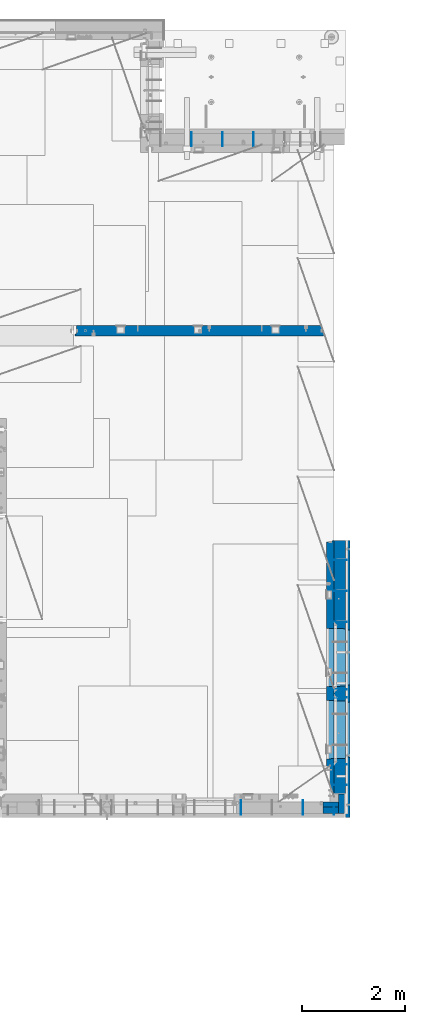
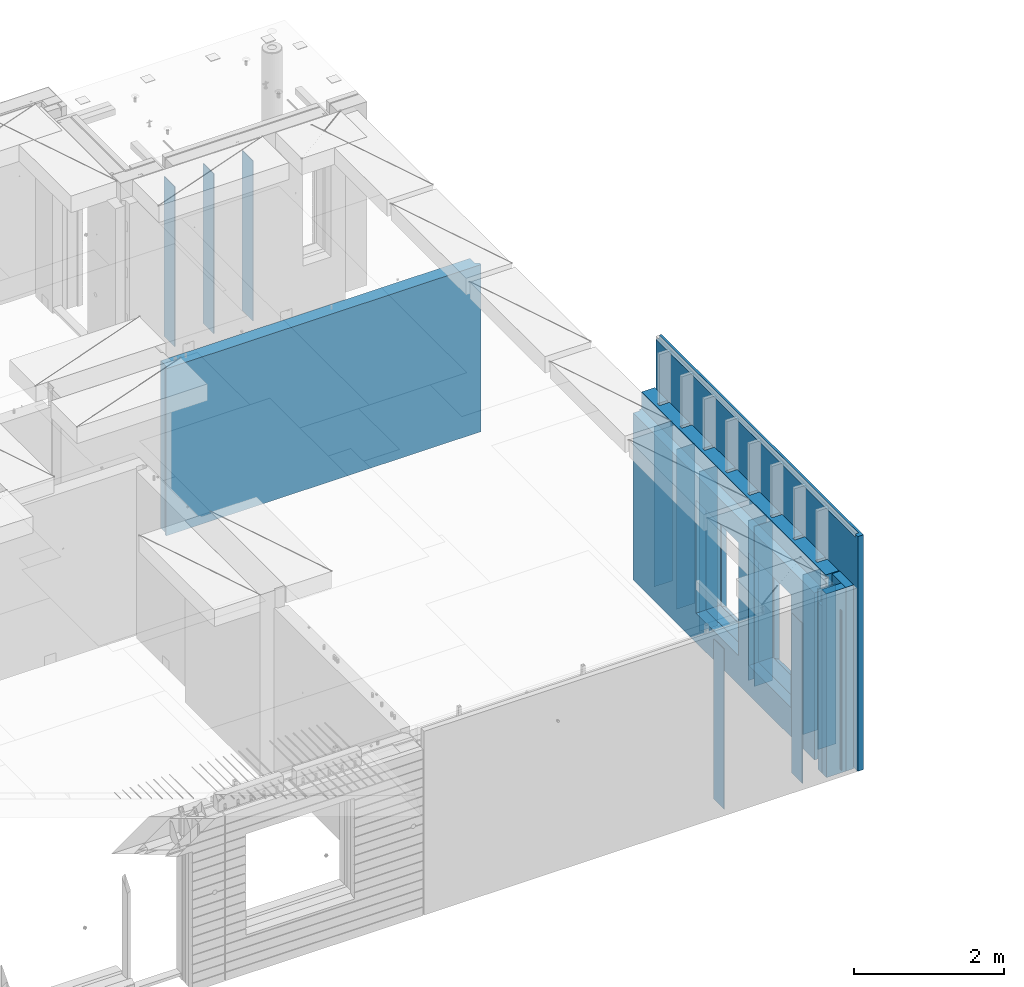
# One storey, part 206 of 309: 20 walls, 4 elements without a shape of their own.
"""IFC2X3 building model written with IfcOpenShell, lengths in millimetres."""

import ifcopenshell
import ifcopenshell.guid

model = None  # the IFC model being written
_history = None  # IfcOwnerHistory: only IFC2X3 demands one
_inside = {}  # id of a spatial element -> (the spatial element, [elements in it])
_under = {}  # id of a project, library or spatial element -> (it, [spatial elements below it])
_declared = {}  # id of a project -> (the project, [libraries it declares])
_typed = {}  # id of a type object -> (the type object, [elements of that type])
_made_of = {}  # id of a material, layer set ... -> (it, [elements and type objects made of it])


def new_model(schema):
    """Start an empty IFC model of exactly this schema.

    Asked for "IFC4X3", IfcOpenShell would pick the latest addendum, in which some entities
    have other attributes; the version numbers below select the first issue.
    IFC2X3 requires an IfcOwnerHistory on every rooted entity: one is made here for all.
    """
    global model, _history
    if schema == "IFC4X3":
        model = ifcopenshell.file(schema_version=(4, 3, 0, 0))
    else:
        model = ifcopenshell.file(schema=schema)
    _inside.clear()
    _under.clear()
    _declared.clear()
    _typed.clear()
    _made_of.clear()
    _history = None
    if model.schema == "IFC2X3":
        org = make("IfcOrganization", Name="unknown")
        user = make(
            "IfcPersonAndOrganization",
            ThePerson=make("IfcPerson", FamilyName="unknown"),
            TheOrganization=org,
        )
        app = make(
            "IfcApplication",
            ApplicationDeveloper=org,
            Version="unknown",
            ApplicationFullName="unknown",
            ApplicationIdentifier="unknown",
        )
        _history = make(
            "IfcOwnerHistory",
            OwningUser=user,
            OwningApplication=app,
            ChangeAction="ADDED",
            CreationDate=0,
        )
    return model


def make(cls, **values):
    """One entity of the class cls with the attributes given. An attribute that is None is left unset."""
    return model.create_entity(
        cls, **{name: value for name, value in values.items() if value is not None}
    )


def rooted(cls, **values):
    """An entity with a GlobalId (a new one), such as an element, a storey or a relation."""
    return make(cls, GlobalId=ifcopenshell.guid.new(), OwnerHistory=_history, **values)


def si_unit(unit_type, name, prefix=None):
    """IfcSIUnit, for example si_unit("LENGTHUNIT", "METRE", prefix="MILLI")."""
    return make("IfcSIUnit", UnitType=unit_type, Prefix=prefix, Name=name)


def assignment(units):
    """IfcUnitAssignment: the units of a project."""
    return None if units is None else make("IfcUnitAssignment", Units=units)


def point(xyz):
    """IfcCartesianPoint."""
    return None if xyz is None else make("IfcCartesianPoint", Coordinates=xyz)


def direction(xyz):
    """IfcDirection."""
    return None if xyz is None else make("IfcDirection", DirectionRatios=xyz)


def frame(location, z_axis=None, x_axis=None):
    """IfcAxis2Placement3D, a coordinate frame: its origin and axes. An axis left out is left unset."""
    return make(
        "IfcAxis2Placement3D",
        Location=point(location),
        Axis=direction(z_axis),
        RefDirection=direction(x_axis),
    )


def origin_with_axes():
    """The frame at (0, 0, 0) with the z axis (0, 0, 1) and the x axis (1, 0, 0) written out."""
    return frame((0.0, 0.0, 0.0), z_axis=(0.0, 0.0, 1.0), x_axis=(1.0, 0.0, 0.0))


def place(relative_to, where):
    """IfcLocalPlacement: puts the frame where relative to a parent placement (None: the world)."""
    return make(
        "IfcLocalPlacement", PlacementRelTo=relative_to, RelativePlacement=where
    )


def context(
    kind, dimensions, precision=None, world=None, true_north=None, identifier=None
):
    """IfcGeometricRepresentationContext, for example the 3D "Model" context."""
    return make(
        "IfcGeometricRepresentationContext",
        ContextIdentifier=identifier,
        ContextType=kind,
        CoordinateSpaceDimension=dimensions,
        Precision=precision,
        WorldCoordinateSystem=world,
        TrueNorth=true_north,
    )


def subcontext(parent, identifier, kind, view, scale=None):
    """IfcGeometricRepresentationSubContext, for example "Body" below "Model"."""
    return make(
        "IfcGeometricRepresentationSubContext",
        ContextIdentifier=identifier,
        ContextType=kind,
        ParentContext=parent,
        TargetScale=scale,
        TargetView=view,
    )


def project(units=None, contexts=None):
    """IfcProject with its units and contexts."""
    return rooted(
        "IfcProject",
        Name="project",
        RepresentationContexts=contexts,
        UnitsInContext=assignment(units),
    )


def spatial(cls, under=None, at=None, **own):
    """A site, building, storey or space (cls), placed at a placement, below another one or the project."""
    s = rooted(cls, ObjectPlacement=at, **own)
    if under is not None:
        _under.setdefault(under.id(), (under, []))[1].append(s)
    return s


def faces_of(points, faces, orient=None, outer=None):
    """IfcFace entities. A face is a list of loops; a loop is a list of indices into points, from 0.

    orient and outer hold one flag for each loop. By default every Orientation is true, the
    first loop of a face is its IfcFaceOuterBound and the others are IfcFaceBound.
    """
    made = []
    for i, loops in enumerate(faces):
        bounds = []
        for j, loop in enumerate(loops):
            is_outer = j == 0 if outer is None else outer[i][j]
            bounds.append(
                make(
                    "IfcFaceOuterBound" if is_outer else "IfcFaceBound",
                    Bound=make("IfcPolyLoop", Polygon=[points[k] for k in loop]),
                    Orientation=True if orient is None else orient[i][j],
                )
            )
        made.append(make("IfcFace", Bounds=bounds))
    return made


def faceted_brep(points, faces, orient=None, outer=None, voids=None):
    """IfcFacetedBrep: a solid bounded by flat faces; with voids (closed shells), ...WithVoids."""
    shared = [point(p) for p in points]
    hull = make("IfcClosedShell", CfsFaces=faces_of(shared, faces, orient, outer))
    if voids is None:
        return make("IfcFacetedBrep", Outer=hull)
    return make(
        "IfcFacetedBrepWithVoids",
        Outer=hull,
        Voids=[
            make(cls, CfsFaces=faces_of(shared, fs, o, b)) for cls, fs, o, b in voids
        ],
    )


def shape(context_of_items, identifier, shape_type, items):
    """IfcShapeRepresentation: the items that make up one representation, for example the "Body"."""
    return make(
        "IfcShapeRepresentation",
        ContextOfItems=context_of_items,
        RepresentationIdentifier=identifier,
        RepresentationType=shape_type,
        Items=items,
    )


def material(Name=None, Category=None):
    """IfcMaterial."""
    return make("IfcMaterial", Name=Name, Category=Category)


def made_of(thing, what):
    """Note that an element or type object is made of a material, layer set ...; save() writes the relation."""
    if what is not None:
        _made_of.setdefault(what.id(), (what, []))[1].append(thing)
    return thing


def type_object(cls, material=None, **own):
    """A type object (cls), such as IfcWallType, which elements share."""
    return made_of(rooted(cls, **own), material)


def element(
    cls,
    number,
    at=None,
    inside=None,
    cuts=None,
    type_object=None,
    material=None,
    context=None,
    identifier="Body",
    shape_type=None,
    held_by="IfcProductDefinitionShape",
    body=None,
    shapes=None,
    **own,
):
    """One element of the class cls, such as IfcWall. Its Tag is "e" and its number.

    at: its placement. inside: the storey or other place that contains it. cuts: it is an
    opening in that element (IfcRelVoidsElement). A single representation is given by context,
    identifier, shape_type and body (its items); several are given by shapes. held_by: the class
    of the entity that holds the representations. save() writes the other relations.
    """
    e = rooted(cls, Tag="e%d" % number, ObjectPlacement=at, **own)
    if body is not None:
        shapes = [shape(context, identifier, shape_type, body)]
    if shapes is not None:
        e.Representation = make(held_by, Representations=shapes)
    if inside is not None:
        _inside.setdefault(inside.id(), (inside, []))[1].append(e)
    if cuts is not None:
        rooted(
            "IfcRelVoidsElement", RelatingBuildingElement=cuts, RelatedOpeningElement=e
        )
    if type_object is not None:
        _typed.setdefault(type_object.id(), (type_object, []))[1].append(e)
    return made_of(e, material)


def aggregate(whole, parts):
    """IfcRelAggregates: a whole, such as a stair, and the parts it consists of."""
    return rooted("IfcRelAggregates", RelatingObject=whole, RelatedObjects=parts)


def save(model, path):
    """Write the relations noted so far, then the file.

    IfcRelAggregates (storeys below a building ...), IfcRelContainedInSpatialStructure (elements
    in a storey), IfcRelDefinesByType, IfcRelAssociatesMaterial and IfcRelDeclares: one each for
    every whole, place, type object, material and project.
    """
    for whole, parts in _under.values():
        aggregate(whole, parts)
    for where, things in _inside.values():
        rooted(
            "IfcRelContainedInSpatialStructure",
            RelatedElements=things,
            RelatingStructure=where,
        )
    for kind, things in _typed.values():
        rooted("IfcRelDefinesByType", RelatedObjects=things, RelatingType=kind)
    for what, things in _made_of.values():
        rooted("IfcRelAssociatesMaterial", RelatedObjects=things, RelatingMaterial=what)
    for by, libraries in _declared.values():
        rooted("IfcRelDeclares", RelatingContext=by, RelatedDefinitions=libraries)
    model.write(path)


model = new_model("IFC2X3")

# Units and contexts
model_context = context("Model", 3, precision=1e-05, world=origin_with_axes())
body_context = subcontext(model_context, "Body", "Model", "MODEL_VIEW")
ifc_project = project(units=[si_unit("LENGTHUNIT", "METRE", prefix="MILLI"), si_unit("AREAUNIT", "SQUARE_METRE"), si_unit("VOLUMEUNIT", "CUBIC_METRE"), si_unit("MASSUNIT", "GRAM", prefix="KILO"), si_unit("TIMEUNIT", "SECOND"), si_unit("PLANEANGLEUNIT", "RADIAN"), si_unit("SOLIDANGLEUNIT", "STERADIAN"), si_unit("THERMODYNAMICTEMPERATUREUNIT", "DEGREE_CELSIUS"), si_unit("LUMINOUSINTENSITYUNIT", "LUMEN")], contexts=[model_context])

# Site, building, storey
site_placement = place(None, origin_with_axes())
site = spatial("IfcSite", under=ifc_project, at=site_placement, CompositionType="ELEMENT")
building_placement = place(site_placement, origin_with_axes())
building = spatial("IfcBuilding", under=site, at=building_placement, CompositionType="ELEMENT")
storey_placement = place(building_placement, origin_with_axes())
storey = spatial("IfcBuildingStorey", under=building, at=storey_placement, Name="7", CompositionType="ELEMENT", Elevation=0.0)

# Assembly, walls
assembly_1_placement = place(storey_placement, origin_with_axes())
assembly_1 = element("IfcElementAssembly", 1, at=assembly_1_placement, inside=storey, AssemblyPlace="NOTDEFINED", PredefinedType="REINFORCEMENT_UNIT")
ifc_material_1 = material(Name="Undefined")
wall_type_1 = type_object("IfcWallType", PredefinedType="NOTDEFINED")
wall_1_placement = place(assembly_1_placement, frame((35030.0, 9870.00028610229, 101115.0), z_axis=(0.0, 0.0, 1.0), x_axis=(1.0, 0.0, 0.0)))
wall_1 = element("IfcWall", 2, at=wall_1_placement, type_object=wall_type_1, material=ifc_material_1, Name="(PD)", context=body_context, shape_type="Brep", body=[
    faceted_brep([(0.0, 5.0, -1300.0), (0.0, 5.0, 1300.0), (280.0, 5.0, 1300.0), (280.0, 5.0, -1300.0), (0.0, -5.0, 1300.0), (280.0, -5.0, 1300.0), (0.0, -5.0, -1300.0), (280.0, -5.0, -1300.0)], [[[0, 1, 2, 3]], [[1, 4, 5, 2]], [[4, 6, 7, 5]], [[6, 0, 3, 7]], [[5, 7, 3, 2]], [[6, 4, 1, 0]]]),
])
wall_2_placement = place(assembly_1_placement, frame((35030.0, 10030.0002861023, 101115.0), z_axis=(0.0, 0.0, 1.0), x_axis=(1.0, 0.0, 0.0)))
wall_2 = element("IfcWall", 3, at=wall_2_placement, type_object=wall_type_1, material=ifc_material_1, Name="(PD)", context=body_context, shape_type="Brep", body=[
    faceted_brep([(0.0, 5.0, -1300.0), (0.0, 5.0, 1300.0), (280.0, 5.0, 1300.0), (280.0, 5.0, -1300.0), (0.0, -5.0, 1300.0), (280.0, -5.0, 1300.0), (0.0, -5.0, -1300.0), (280.0, -5.0, -1300.0)], [[[0, 1, 2, 3]], [[1, 4, 5, 2]], [[4, 6, 7, 5]], [[6, 0, 3, 7]], [[5, 7, 3, 2]], [[6, 4, 1, 0]]]),
])
wall_3_placement = place(assembly_1_placement, frame((35030.0, 8580.0, 101115.0), z_axis=(0.0, 0.0, 1.0), x_axis=(1.0, 0.0, 0.0)))
wall_3 = element("IfcWall", 4, at=wall_3_placement, type_object=wall_type_1, material=ifc_material_1, Name="(PD)", context=body_context, shape_type="Brep", body=[
    faceted_brep([(0.0, 5.0, -1300.0), (0.0, 5.0, 1300.0), (280.0, 5.0, 1300.0), (280.0, 5.0, -1300.0), (0.0, -5.0, 1300.0), (280.0, -5.0, 1300.0), (0.0, -5.0, -1300.0), (280.0, -5.0, -1300.0)], [[[0, 1, 2, 3]], [[1, 4, 5, 2]], [[4, 6, 7, 5]], [[6, 0, 3, 7]], [[5, 7, 3, 2]], [[6, 4, 1, 0]]]),
])
wall_4_placement = place(assembly_1_placement, frame((35030.0, 12540.0002861023, 101115.0), z_axis=(0.0, 0.0, 1.0), x_axis=(1.0, 0.0, 0.0)))
wall_4 = element("IfcWall", 5, at=wall_4_placement, type_object=wall_type_1, material=ifc_material_1, Name="(PD)", context=body_context, shape_type="Brep", body=[
    faceted_brep([(0.0, 5.0, -1300.0), (0.0, 5.0, 1300.0), (280.0, 5.0, 1300.0), (280.0, 5.0, -1300.0), (0.0, -5.0, 1300.0), (280.0, -5.0, 1300.0), (0.0, -5.0, -1300.0), (280.0, -5.0, -1300.0)], [[[0, 1, 2, 3]], [[1, 4, 5, 2]], [[4, 6, 7, 5]], [[6, 0, 3, 7]], [[5, 7, 3, 2]], [[6, 4, 1, 0]]]),
])
wall_5_placement = place(assembly_1_placement, frame((35030.0, 11940.0002861023, 101115.0), z_axis=(0.0, 0.0, 1.0), x_axis=(1.0, 0.0, 0.0)))
wall_5 = element("IfcWall", 6, at=wall_5_placement, type_object=wall_type_1, material=ifc_material_1, Name="(PD)", context=body_context, shape_type="Brep", body=[
    faceted_brep([(0.0, 5.0, -1300.0), (0.0, 5.0, 1300.0), (280.0, 5.0, 1300.0), (280.0, 5.0, -1300.0), (0.0, -5.0, 1300.0), (280.0, -5.0, 1300.0), (0.0, -5.0, -1300.0), (280.0, -5.0, -1300.0)], [[[0, 1, 2, 3]], [[1, 4, 5, 2]], [[4, 6, 7, 5]], [[6, 0, 3, 7]], [[5, 7, 3, 2]], [[6, 4, 1, 0]]]),
])

assembly_2_placement = place(storey_placement, origin_with_axes())
assembly_2 = element("IfcElementAssembly", 7, at=assembly_2_placement, inside=storey, AssemblyPlace="NOTDEFINED", PredefinedType="REINFORCEMENT_UNIT")
wall_6_placement = place(assembly_2_placement, frame((32295.0, 20549.9951872276, 101115.0), z_axis=(0.0, 0.0, 1.0), x_axis=(0.0, 1.0, 0.0)))
wall_6 = element("IfcWall", 8, at=wall_6_placement, type_object=wall_type_1, material=ifc_material_1, Name="(PD)", context=body_context, shape_type="Brep", body=[
    faceted_brep([(0.0, 5.0, -1300.0), (0.0, 5.0, 1300.0), (280.0, 5.0, 1300.0), (280.0, 5.0, -1300.0), (0.0, -5.0, 1300.0), (280.0, -5.0, 1300.0), (0.0, -5.0, -1300.0), (280.0, -5.0, -1300.0)], [[[0, 1, 2, 3]], [[1, 4, 5, 2]], [[4, 6, 7, 5]], [[6, 0, 3, 7]], [[5, 7, 3, 2]], [[6, 4, 1, 0]]]),
])
wall_7_placement = place(assembly_2_placement, frame((32895.0, 20549.9951872276, 101115.0), z_axis=(0.0, 0.0, 1.0), x_axis=(0.0, 1.0, 0.0)))
wall_7 = element("IfcWall", 9, at=wall_7_placement, type_object=wall_type_1, material=ifc_material_1, Name="(PD)", context=body_context, shape_type="Brep", body=[
    faceted_brep([(0.0, 5.0, -1300.0), (0.0, 5.0, 1300.0), (280.0, 5.0, 1300.0), (280.0, 5.0, -1300.0), (0.0, -5.0, 1300.0), (280.0, -5.0, 1300.0), (0.0, -5.0, -1300.0), (280.0, -5.0, -1300.0)], [[[0, 1, 2, 3]], [[1, 4, 5, 2]], [[4, 6, 7, 5]], [[6, 0, 3, 7]], [[5, 7, 3, 2]], [[6, 4, 1, 0]]]),
])
wall_8_placement = place(assembly_2_placement, frame((33495.0, 20549.9951872276, 101115.0), z_axis=(0.0, 0.0, 1.0), x_axis=(0.0, 1.0, 0.0)))
wall_8 = element("IfcWall", 10, at=wall_8_placement, type_object=wall_type_1, material=ifc_material_1, Name="(PD)", context=body_context, shape_type="Brep", body=[
    faceted_brep([(0.0, 5.0, -1300.0), (0.0, 5.0, 1300.0), (280.0, 5.0, 1300.0), (280.0, 5.0, -1300.0), (0.0, -5.0, 1300.0), (280.0, -5.0, 1300.0), (0.0, -5.0, -1300.0), (280.0, -5.0, -1300.0)], [[[0, 1, 2, 3]], [[1, 4, 5, 2]], [[4, 6, 7, 5]], [[6, 0, 3, 7]], [[5, 7, 3, 2]], [[6, 4, 1, 0]]]),
])
aggregate(assembly_2, [wall_6, wall_7, wall_8])

assembly_3_placement = place(storey_placement, origin_with_axes())
assembly_3 = element("IfcElementAssembly", 11, at=assembly_3_placement, inside=storey, AssemblyPlace="NOTDEFINED", PredefinedType="REINFORCEMENT_UNIT")
wall_9_placement = place(assembly_3_placement, frame((35060.0, 7780.0, 101115.0), z_axis=(0.0, 0.0, 1.0), x_axis=(0.0, -1.0, 0.0)))
wall_9 = element("IfcWall", 12, at=wall_9_placement, type_object=wall_type_1, material=ifc_material_1, Name="(PD)", context=body_context, shape_type="Brep", body=[
    faceted_brep([(0.0, 5.0, -1300.0), (0.0, 5.0, 1300.0), (180.0, 5.0, 1300.0), (180.0, 5.0, -1300.0), (0.0, -5.0, 1300.0), (180.0, -5.0, 1300.0), (0.0, -5.0, -1300.0), (180.0, -5.0, -1300.0)], [[[0, 1, 2, 3]], [[1, 4, 5, 2]], [[4, 6, 7, 5]], [[6, 0, 3, 7]], [[5, 7, 3, 2]], [[6, 4, 1, 0]]]),
])
wall_10_placement = place(assembly_3_placement, frame((34460.0, 7880.0, 101115.0), z_axis=(0.0, 0.0, 1.0), x_axis=(0.0, -1.0, 0.0)))
wall_10 = element("IfcWall", 13, at=wall_10_placement, type_object=wall_type_1, material=ifc_material_1, Name="(PD)", context=body_context, shape_type="Brep", body=[
    faceted_brep([(0.0, 5.0, -1300.0), (0.0, 5.0, 1300.0), (280.0, 5.0, 1300.0), (280.0, 5.0, -1300.0), (0.0, -5.0, 1300.0), (280.0, -5.0, 1300.0), (0.0, -5.0, -1300.0), (280.0, -5.0, -1300.0)], [[[0, 1, 2, 3]], [[1, 4, 5, 2]], [[4, 6, 7, 5]], [[6, 0, 3, 7]], [[5, 7, 3, 2]], [[6, 4, 1, 0]]]),
])
wall_11_placement = place(assembly_3_placement, frame((33260.0, 7880.0, 101115.0), z_axis=(0.0, 0.0, 1.0), x_axis=(0.0, -1.0, 0.0)))
wall_11 = element("IfcWall", 14, at=wall_11_placement, type_object=wall_type_1, material=ifc_material_1, Name="(PD)", context=body_context, shape_type="Brep", body=[
    faceted_brep([(0.0, 5.0, -1300.0), (0.0, 5.0, 1300.0), (280.0, 5.0, 1300.0), (280.0, 5.0, -1300.0), (0.0, -5.0, 1300.0), (280.0, -5.0, 1300.0), (0.0, -5.0, -1300.0), (280.0, -5.0, -1300.0)], [[[0, 1, 2, 3]], [[1, 4, 5, 2]], [[4, 6, 7, 5]], [[6, 0, 3, 7]], [[5, 7, 3, 2]], [[6, 4, 1, 0]]]),
])

# Wall
wall_12_placement = place(assembly_1_placement, frame((35030.0, 11340.0002861023, 101115.0), z_axis=(0.0, 0.0, 1.0), x_axis=(1.0, 0.0, 0.0)))
wall_12 = element("IfcWall", 15, at=wall_12_placement, type_object=wall_type_1, material=ifc_material_1, Name="(PD)", context=body_context, shape_type="Brep", body=[
    faceted_brep([(0.0, 5.0, -1300.0), (0.0, 5.0, 1300.0), (280.0, 5.0, 1300.0), (280.0, 5.0, -1300.0), (0.0, -5.0, 1300.0), (280.0, -5.0, 1300.0), (0.0, -5.0, -1300.0), (280.0, -5.0, -1300.0)], [[[0, 1, 2, 3]], [[1, 4, 5, 2]], [[4, 6, 7, 5]], [[6, 0, 3, 7]], [[5, 7, 3, 2]], [[6, 4, 1, 0]]]),
])

wall_13_placement = place(assembly_1_placement, frame((35030.0, 8180.0, 101115.0), z_axis=(0.0, 0.0, 1.0), x_axis=(1.0, 0.0, 0.0)))
wall_13 = element("IfcWall", 16, at=wall_13_placement, type_object=wall_type_1, material=ifc_material_1, Name="(PD)", context=body_context, shape_type="Brep", body=[
    faceted_brep([(0.0, 5.0, -1300.0), (0.0, 5.0, 1300.0), (280.0, 5.0, 1300.0), (280.0, 5.0, -1300.0), (0.0, -5.0, 1300.0), (280.0, -5.0, 1300.0), (0.0, -5.0, -1300.0), (280.0, -5.0, -1300.0)], [[[0, 1, 2, 3]], [[1, 4, 5, 2]], [[4, 6, 7, 5]], [[6, 0, 3, 7]], [[5, 7, 3, 2]], [[6, 4, 1, 0]]]),
])

# Assembly, wall
assembly_4_placement = place(storey_placement, origin_with_axes())
assembly_4 = element("IfcElementAssembly", 17, at=assembly_4_placement, inside=storey, AssemblyPlace="NOTDEFINED", PredefinedType="REINFORCEMENT_UNIT")
ifc_material_2 = material(Name="CONCRETE/C25/30")
wall_type_2 = type_object("IfcWallType", PredefinedType="NOTDEFINED")
wall_14_placement = place(assembly_4_placement, frame((30040.0, 16980.0002441406, 101112.5), z_axis=(0.0, 0.0, 1.0), x_axis=(1.0, 0.0, 0.0)))
wall_14 = element("IfcWall", 18, at=wall_14_placement, type_object=wall_type_2, material=ifc_material_2, context=body_context, shape_type="Brep", body=[
    faceted_brep([(4785.0, 100.0, 1357.5), (4785.0, -30.0, 1357.5), (4785.0, -30.0, -1357.5), (4785.0, 100.0, -1357.5), (4840.0, -60.0, 1357.5), (4840.0, -60.0, -1357.5), (30.0003214753524, 100.0, 1357.5), (30.0003214753524, 100.0, -1357.5), (30.0003214753524, -57.0, -1357.5), (30.0003214753524, -57.0, 1357.5), (0.0, -70.0001393059865, -1357.5), (0.0, -70.0001393059865, 1357.5), (0.0, -100.0, -1357.5), (0.0, -100.0, 1357.5), (4840.0, -100.0, -1357.5), (4840.0, -100.0, 1357.5)], [[[0, 1, 2, 3]], [[4, 5, 2, 1]], [[6, 7, 8, 9]], [[9, 8, 10, 11]], [[12, 13, 11, 10]], [[13, 12, 14, 15]], [[0, 6, 9, 11, 13, 15, 4, 1]], [[7, 6, 0, 3]], [[14, 12, 10, 8, 7, 3, 2, 5]], [[15, 14, 5, 4]]]),
])
aggregate(assembly_4, [wall_14])

# Wall
ifc_material_3 = material(Name="COS5gt")
wall_type_3 = type_object("IfcWallType", PredefinedType="NOTDEFINED")
wall_15_placement = place(assembly_1_placement, frame((35170.0, 12920.0002861023, 101247.5), z_axis=(0.0, 0.0, 1.0), x_axis=(0.0, -1.0, 0.0)))
wall_15 = element("IfcWall", 19, at=wall_15_placement, type_object=wall_type_3, material=ifc_material_3, context=body_context, shape_type="Brep", body=[
    faceted_brep([(4595.00004196167, -65.0, 1492.5), (4595.00004196167, -65.0, 622.5), (4545.00004196167, -65.0, 622.5), (4545.00004196167, -65.0, 1492.5), (4595.00004196167, 110.0, 1442.5), (4595.00004196167, 110.0, 622.5), (4595.00004196167, 90.0, 1492.5), (4595.00004196167, 90.0, 1442.5), (4545.00004196167, 110.0, 622.5), (4545.00004196167, 110.0, 1442.5), (4545.00004196167, 90.0, 1442.5), (4545.00004196167, 90.0, 1492.5), (3395.00004196167, 110.0, 1442.5), (3395.00004196167, 90.0, 1442.5), (3945.00004196167, 90.0, 1442.5), (3945.00004196167, 110.0, 1442.5), (2795.00004196167, 110.0, 1442.5), (2795.00004196167, 90.0, 1442.5), (3345.00004196167, 90.0, 1442.5), (3345.00004196167, 110.0, 1442.5), (2195.00004196167, 110.0, 1442.5), (2195.00004196167, 90.0, 1442.5), (2745.00004196167, 90.0, 1442.5), (2745.00004196167, 110.0, 1442.5), (1595.00004196167, 110.0, 1442.5), (1595.00004196167, 90.0, 1442.5), (2145.00004196167, 90.0, 1442.5), (2145.00004196167, 110.0, 1442.5), (995.00004196167, 110.0, 1442.5), (995.00004196167, 90.0, 1442.5), (1545.00004196167, 90.0, 1442.5), (1545.00004196167, 110.0, 1442.5), (394.999999999998, 110.0, 1442.5), (394.999999999998, 90.0, 1442.5), (945.00004196167, 90.0, 1442.5), (945.00004196167, 110.0, 1442.5), (-0.25, 110.0, 1442.5), (-0.25, 90.0, 1442.5), (345.00004196167, 90.0, 1442.5), (345.00004196167, 110.0, 1442.5), (4905.00028610229, 110.0, 1442.5), (4905.00028610229, 90.0, 1442.5), (4905.00028610229, 90.0, 1492.5), (4905.00028610229, -110.0, 1492.5), (4905.00028610229, -110.0, -1492.5), (4905.00028610229, 90.0, -1492.5), (4905.00028610229, 90.0, -1442.5), (4905.00028610229, 110.0, -1442.5), (2825.00062480275, 110.0, -1002.5), (2825.00062480275, 110.0, -1007.5), (2830.9465707487, -110.0, -1013.44594594595), (2830.9465707487, -110.0, 813.445945945947), (2825.00062480275, 110.0, 807.5), (2795.00062480275, 110.0, -1007.5), (1745.00062480275, 110.0, -1007.5), (1715.00062480275, 110.0, -1007.5), (1709.0546788568, -110.0, -1013.44594594595), (1715.00062480275, 110.0, -1002.5), (1715.00062480275, 110.0, 807.5), (1709.0546788568, -110.0, 813.445945945947), (4225.00024333302, 110.0, -1002.5), (4225.00024333302, 110.0, -1007.5), (4230.94618927897, -110.0, -1013.44594594595), (4230.94618927897, -110.0, 813.445945945947), (4225.00024333302, 110.0, 807.5), (4195.00024333302, 110.0, -1007.5), (3145.00024333302, 110.0, -1007.5), (3115.00024333302, 110.0, -1007.5), (3109.05429738708, -110.0, -1013.44594594595), (3115.00024333302, 110.0, -1002.5), (3115.00024333302, 110.0, 807.5), (3109.05429738708, -110.0, 813.445945945947), (0.0, -110.0, 1492.5), (0.0, -110.0, -1492.5), (0.0, 90.0, -1492.5), (-0.25, 90.0, -1442.5), (-0.25, 110.0, -1442.5), (0.0, 90.0, 1492.5), (345.00004196167, 90.0, 1492.5), (345.00004196167, 110.0, 622.5), (345.00004196167, -65.0, 622.5), (395.00004196167, -65.0, 622.5), (395.00004196167, 110.0, 622.5), (345.00004196167, -65.0, 1492.5), (395.00004196167, -65.0, 1492.5), (394.999999999998, 90.0, 1492.5), (945.00004196167, 90.0, 1492.5), (945.00004196167, 110.0, 622.5), (945.00004196167, -65.0, 622.5), (995.00004196167, -65.0, 622.5), (995.00004196167, 110.0, 622.5), (945.00004196167, -65.0, 1492.5), (995.00004196167, -65.0, 1492.5), (995.00004196167, 90.0, 1492.5), (1545.00004196167, 90.0, 1492.5), (1545.00004196167, 110.0, 622.5), (1545.00004196167, -65.0, 622.5), (1595.00004196167, -65.0, 622.5), (1595.00004196167, 110.0, 622.5), (1545.00004196167, -65.0, 1492.5), (1595.00004196167, -65.0, 1492.5), (1595.00004196167, 90.0, 1492.5), (2145.00004196167, 90.0, 1492.5), (2145.00004196167, 110.0, 817.5), (2145.00004196167, -65.0, 817.5), (2195.00004196167, -65.0, 817.5), (2195.00004196167, 110.0, 817.5), (2145.00004196167, -65.0, 1492.5), (2195.00004196167, -65.0, 1492.5), (2195.00004196167, 90.0, 1492.5), (2745.00004196167, 90.0, 1492.5), (2745.00004196167, 110.0, 817.5), (2745.00004196167, -65.0, 817.5), (2795.00004196167, -65.0, 817.5), (2795.00004196167, 110.0, 817.5), (2745.00004196167, -65.0, 1492.5), (2795.00004196167, -65.0, 1492.5), (2795.00004196167, 90.0, 1492.5), (3345.00004196167, 90.0, 1492.5), (3345.00004196167, 110.0, 817.5), (3345.00004196167, -65.0, 817.5), (3395.00004196167, -65.0, 817.5), (3395.00004196167, 110.0, 817.5), (3345.00004196167, -65.0, 1492.5), (3395.00004196167, -65.0, 1492.5), (3395.00004196167, 90.0, 1492.5), (3945.00004196167, 90.0, 1492.5), (3945.00004196167, 110.0, 817.5), (3945.00004196167, -65.0, 817.5), (3995.00004196167, -65.0, 817.5), (3995.00004196167, 110.0, 817.5), (3945.00004196167, -65.0, 1492.5), (3995.00004196167, -65.0, 1492.5), (3995.00004196167, 110.0, 1442.5), (3995.00004196167, 90.0, 1492.5), (3995.00004196167, 90.0, 1442.5)], [[[0, 1, 2, 3]], [[4, 5, 1, 0, 6, 7]], [[8, 2, 1, 5]], [[9, 10, 11, 3, 2, 8]], [[12, 13, 14, 15]], [[16, 17, 18, 19]], [[20, 21, 22, 23]], [[24, 25, 26, 27]], [[28, 29, 30, 31]], [[32, 33, 34, 35]], [[36, 37, 38, 39]], [[40, 41, 42, 43, 44, 45, 46, 47]], [[48, 49, 50, 51, 52]], [[53, 54, 55, 56, 50, 49]], [[57, 58, 59, 56, 55]], [[52, 51, 59, 58]], [[60, 61, 62, 63, 64]], [[65, 66, 67, 68, 62, 61]], [[69, 70, 71, 68, 67]], [[64, 63, 71, 70]], [[72, 73, 44, 43], [62, 68, 71, 63], [50, 56, 59, 51]], [[44, 73, 74, 45]], [[75, 46, 45, 74]], [[76, 47, 46, 75]], [[74, 73, 72, 77, 37, 36, 76, 75]], [[37, 77, 78, 38]], [[79, 80, 81, 82]], [[39, 38, 78, 83, 80, 79]], [[84, 81, 80, 83]], [[32, 82, 81, 84, 85, 33]], [[33, 85, 86, 34]], [[87, 88, 89, 90]], [[35, 34, 86, 91, 88, 87]], [[92, 89, 88, 91]], [[28, 90, 89, 92, 93, 29]], [[29, 93, 94, 30]], [[95, 96, 97, 98]], [[31, 30, 94, 99, 96, 95]], [[100, 97, 96, 99]], [[24, 98, 97, 100, 101, 25]], [[25, 101, 102, 26]], [[103, 104, 105, 106]], [[27, 26, 102, 107, 104, 103]], [[108, 105, 104, 107]], [[20, 106, 105, 108, 109, 21]], [[21, 109, 110, 22]], [[111, 112, 113, 114]], [[23, 22, 110, 115, 112, 111]], [[116, 113, 112, 115]], [[16, 114, 113, 116, 117, 17]], [[17, 117, 118, 18]], [[119, 120, 121, 122]], [[19, 18, 118, 123, 120, 119]], [[124, 121, 120, 123]], [[12, 122, 121, 124, 125, 13]], [[13, 125, 126, 14]], [[127, 128, 129, 130]], [[15, 14, 126, 131, 128, 127]], [[132, 129, 128, 131]], [[133, 130, 129, 132, 134, 135]], [[5, 4, 40, 47, 76, 36, 39, 79, 82, 32, 35, 87, 90, 28, 31, 95, 98, 24, 27, 103, 106, 20, 23, 111, 114, 16, 19, 119, 122, 12, 15, 127, 130, 133, 9, 8], [67, 66, 65, 61, 60, 64, 70, 69], [55, 54, 53, 49, 48, 52, 58, 57]], [[41, 40, 4, 7]], [[42, 41, 7, 6]], [[134, 132, 131, 126, 125, 124, 123, 118, 117, 116, 115, 110, 109, 108, 107, 102, 101, 100, 99, 94, 93, 92, 91, 86, 85, 84, 83, 78, 77, 72, 43, 42, 6, 0, 3, 11]], [[135, 134, 11, 10]], [[133, 135, 10, 9]]]),
])

wall_type_4 = type_object("IfcWallType", PredefinedType="NOTDEFINED")
wall_16_placement = place(assembly_1_placement, frame((34985.0, 12920.0002861023, 101112.5), z_axis=(0.0, 0.0, 1.0), x_axis=(0.0, -1.0, 0.0)))
wall_16 = element("IfcWall", 20, at=wall_16_placement, type_object=wall_type_4, material=ifc_material_2, context=body_context, shape_type="Brep", body=[
    faceted_brep([(4855.00028610229, -75.0, 1357.5), (4855.00028610229, -75.0, -1357.5), (4855.00028610229, 32.0000069488524, -1357.5), (4855.00028610229, 32.0000069488524, 1357.5), (4905.00028610229, 45.0000069488524, 1357.5), (4905.00028610229, 45.0000069488524, -1357.5), (29.9999989126591, 32.0000004547946, 1357.5), (29.9999989126591, 32.0000004547946, -1357.5), (30.0000016637459, -75.0, -1357.5), (30.0000016637459, -75.0, 1357.5), (0.0, 45.0, 1357.5), (0.0, 45.0, -1357.5), (0.0, 75.0, 1357.5), (0.0, 75.0, -1357.5), (4905.00028610229, 75.0, -1357.5), (4905.00028610229, 75.0, 1357.5), (4230.94618927897, 75.0, 948.445945945947), (4235.00024333302, -75.0, 952.5), (3105.00024333302, -75.0, 952.5), (3109.05429738708, 75.0, 948.445945945947), (4230.94618927897, 75.0, -878.445945945947), (4235.00024333302, -75.0, -882.5), (3109.05429738708, 75.0, -878.445945945947), (3105.00024333302, -75.0, -882.5), (2830.9465707487, 75.0, -878.445945945947), (2830.9465707487, 75.0, 948.445945945947), (1709.0546788568, 75.0, 948.445945945947), (1709.0546788568, 75.0, -878.445945945947), (2835.00062480275, -75.0, -882.5), (2835.00062480275, -75.0, 952.5), (1705.00062480275, -75.0, -882.5), (1705.00062480275, -75.0, 952.5)], [[[0, 1, 2, 3]], [[4, 3, 2, 5]], [[6, 7, 8, 9]], [[10, 11, 7, 6]], [[12, 13, 11, 10]], [[1, 8, 7, 11, 13, 14, 5, 2]], [[14, 15, 4, 5]], [[16, 17, 18, 19]], [[20, 21, 17, 16]], [[22, 23, 21, 20]], [[19, 18, 23, 22]], [[13, 12, 15, 14], [20, 16, 19, 22], [24, 25, 26, 27]], [[24, 28, 29, 25]], [[27, 30, 28, 24]], [[26, 31, 30, 27]], [[25, 29, 31, 26]], [[9, 8, 1, 0], [28, 30, 31, 29], [21, 23, 18, 17]], [[15, 12, 10, 6, 9, 0, 3, 4]]]),
])

ifc_material_4 = material(Name="CONCRETE/C30/37")
wall_type_5 = type_object("IfcWallType", PredefinedType="NOTDEFINED")
wall_17_placement = place(assembly_1_placement, frame((35322.5, 12920.2502861023, 101662.5), z_axis=(0.0, 0.0, 1.0), x_axis=(0.0, -1.0, 0.0)))
wall_17 = element("IfcWall", 21, at=wall_17_placement, type_object=wall_type_5, material=ifc_material_4, context=body_context, shape_type="Brep", body=[
    faceted_brep([(0.0, -42.5, 1857.5), (5305.25028610229, -42.5, 1857.5), (5305.25028610229, 7.5, 1857.5), (0.0, 7.5, 1857.5), (5305.25028610229, 7.5, 1907.5), (5305.25028610229, -42.5, 1907.5), (0.0, 7.5, 1907.5), (5375.25028610229, -42.5, 1907.5), (5375.25028610229, 42.5, 1907.5), (0.0, 42.5, 1907.5), (0.0, -42.5, -1907.5), (0.0, 42.5, -1907.5), (5375.25028610229, 42.5, -1907.5), (5375.25028610229, -42.5, -1907.5), (1745.25062480275, 42.5, 367.5), (2795.25062480275, 42.5, 367.5), (2805.25062480275, 42.5, 367.5), (2795.25062480275, -42.5, 372.5), (1745.25062480275, -42.5, 372.5), (1735.25062480275, 42.5, 367.5), (2805.25062480275, 42.5, -1472.5), (2795.25062480275, -42.5, -1422.5), (2795.25062480275, -42.5, 367.5), (1735.25062480275, 42.5, -1472.5), (1745.25062480275, -42.5, -1422.5), (1745.25062480275, -42.5, 367.5), (4205.25024333302, 42.5, -1472.5), (4205.25024333302, 42.5, 367.5), (4195.25024333302, 42.5, 367.5), (3145.25024333302, 42.5, 367.5), (3135.25024333302, 42.5, 367.5), (3135.25024333302, 42.5, -1472.5), (4195.25024333302, -42.5, -1422.5), (4195.25024333302, -42.5, 367.5), (4195.25024333302, -42.5, 372.5), (3145.25024333302, -42.5, -1422.5), (3145.25024333302, -42.5, 372.5), (3145.25024333302, -42.5, 367.5)], [[[0, 1, 2, 3]], [[4, 2, 1, 5]], [[6, 3, 2, 4]], [[5, 7, 8, 9, 6, 4]], [[10, 11, 12, 13]], [[7, 13, 12, 8]], [[14, 15, 16, 17, 18, 19]], [[20, 21, 22, 17, 16]], [[23, 24, 21, 20]], [[19, 18, 25, 24, 23]], [[11, 9, 8, 12], [20, 16, 15, 14, 19, 23], [26, 27, 28, 29, 30, 31]], [[26, 32, 33, 34, 27]], [[31, 35, 32, 26]], [[30, 36, 37, 35, 31]], [[29, 28, 27, 34, 36, 30]], [[10, 13, 7, 5, 1, 0], [33, 32, 35, 37, 36, 34], [22, 21, 24, 25, 18, 17]], [[9, 11, 10, 0, 3, 6]]]),
])

aggregate(assembly_1, [wall_1, wall_2, wall_3, wall_4, wall_5, wall_12, wall_13, wall_17, wall_15, wall_16])

ifc_material_5 = material(Name="CONCRETE/C35/45")
wall_type_6 = type_object("IfcWallType", PredefinedType="NOTDEFINED")
wall_18_placement = place(assembly_3_placement, frame((35145.0000381475, 7800.0, 101112.5), z_axis=(0.0, 0.0, 1.0), x_axis=(-1.0, 3.00000001838171e-08, 0.0)))
wall_18 = element("IfcWall", 22, at=wall_18_placement, type_object=wall_type_6, material=ifc_material_5, context=body_context, shape_type="Brep", body=[
    faceted_brep([(0.0, 50.0, -1357.5), (0.0, 50.0, 1357.5), (300.001908754726, 50.0, 1357.5), (300.001908754726, 50.0, -1357.5), (0.0, -50.0, 1357.5), (300.001908754726, -50.0, 1357.5), (0.0, -50.0, -1357.5), (300.001908754726, -50.0, -1357.5)], [[[0, 1, 2, 3]], [[1, 4, 5, 2]], [[4, 6, 7, 5]], [[6, 0, 3, 7]], [[5, 7, 3, 2]], [[6, 4, 1, 0]]]),
])

ifc_material_6 = material(Name="SPU")
wall_type_7 = type_object("IfcWallType", PredefinedType="NOTDEFINED")
wall_19_placement = place(assembly_3_placement, frame((35145.0000381475, 7690.0, 101247.5), z_axis=(0.0, 0.0, 1.0), x_axis=(-1.0, 3.00000001838171e-08, 0.0)))
wall_19 = element("IfcWall", 23, at=wall_19_placement, type_object=wall_type_7, material=ifc_material_6, context=body_context, shape_type="Brep", body=[
    faceted_brep([(0.0, 60.0, -1492.5), (0.0, 60.0, 1492.5), (300.001908754726, 60.0, 1492.5), (300.001908754726, 60.0, -1492.5), (0.0, -60.0, 1492.5), (300.001908754726, -60.0, 1492.5), (0.0, -60.0, -1492.5), (300.001908754726, -60.0, -1492.5)], [[[0, 1, 2, 3]], [[1, 4, 5, 2]], [[4, 6, 7, 5]], [[6, 0, 3, 7]], [[5, 7, 3, 2]], [[6, 4, 1, 0]]]),
])

wall_20_placement = place(assembly_3_placement, frame((35205.0, 8000.0, 101247.5), z_axis=(0.0, 0.0, 1.0), x_axis=(0.0, -1.0, 0.0)))
wall_20 = element("IfcWall", 24, at=wall_20_placement, type_object=wall_type_7, material=ifc_material_6, context=body_context, shape_type="Brep", body=[
    faceted_brep([(0.0, 60.0, -1492.5), (0.0, 60.0, 1492.5), (370.0, 60.0, 1492.5), (370.0, 60.0, -1492.5), (0.0, -60.0, 1492.5), (370.0, -60.0, 1492.5), (0.0, -60.0, -1492.5), (370.0, -60.0, -1492.5)], [[[0, 1, 2, 3]], [[1, 4, 5, 2]], [[4, 6, 7, 5]], [[6, 0, 3, 7]], [[5, 7, 3, 2]], [[6, 4, 1, 0]]]),
])

aggregate(assembly_3, [wall_19, wall_18, wall_9, wall_10, wall_20, wall_11])

save(model, "model.ifc")
